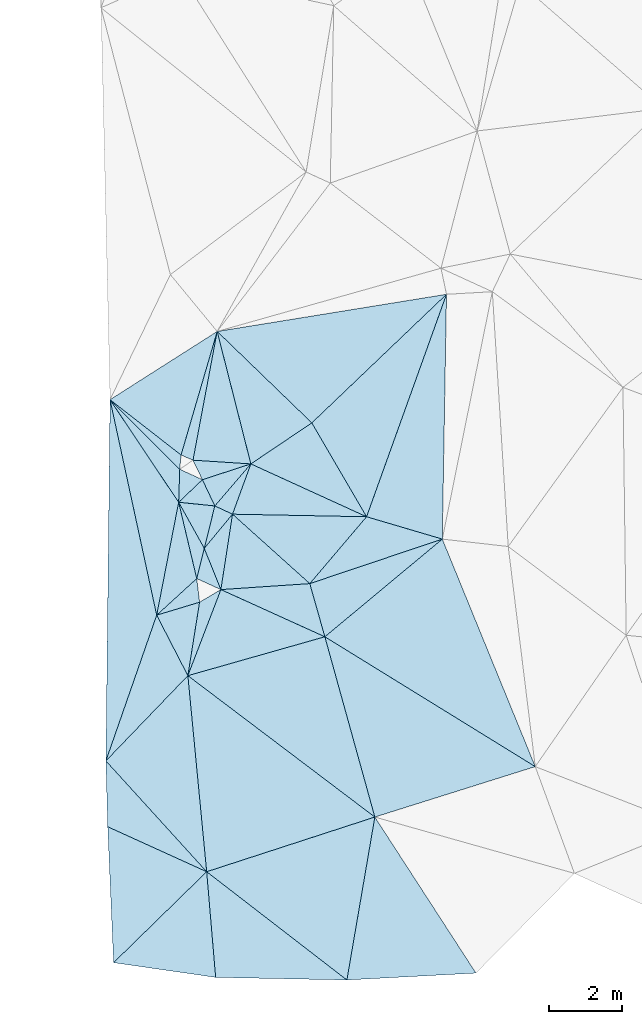
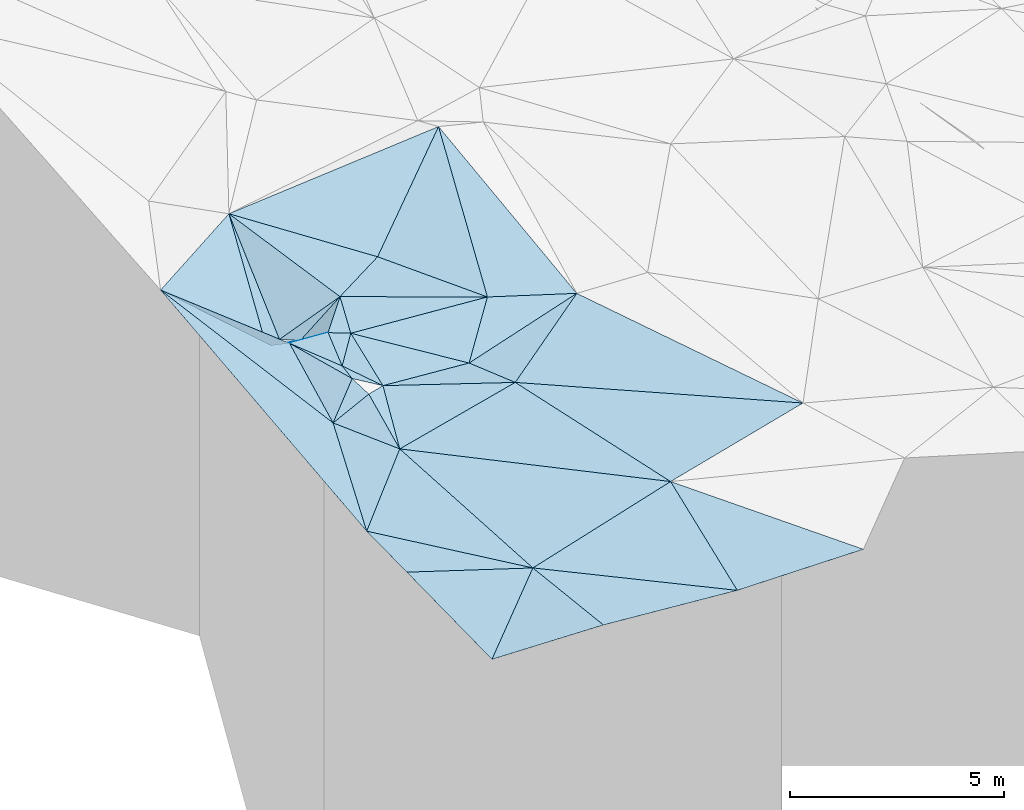
# One storey, part 1 of 275: 45 plates.
"""IFC2X3 building model written with IfcOpenShell, lengths in millimetres."""

from ifc_helpers import new_model, si_unit, frame, origin_with_axes, place, context, subcontext, project, spatial, polyline, outline, extrude, material, type_object, element, save


model = new_model("IFC2X3")

# Units and contexts
model_context = context("Model", 3, precision=1e-05, world=origin_with_axes())
body_context = subcontext(model_context, "Body", "Model", "MODEL_VIEW")
ifc_project = project(units=[si_unit("LENGTHUNIT", "METRE", prefix="MILLI"), si_unit("AREAUNIT", "SQUARE_METRE"), si_unit("VOLUMEUNIT", "CUBIC_METRE"), si_unit("MASSUNIT", "GRAM", prefix="KILO"), si_unit("TIMEUNIT", "SECOND"), si_unit("PLANEANGLEUNIT", "RADIAN"), si_unit("SOLIDANGLEUNIT", "STERADIAN"), si_unit("THERMODYNAMICTEMPERATUREUNIT", "DEGREE_CELSIUS"), si_unit("LUMINOUSINTENSITYUNIT", "LUMEN")], contexts=[model_context])

# Site, building, storey
site_placement = place(None, origin_with_axes())
site = spatial("IfcSite", under=ifc_project, at=site_placement, CompositionType="ELEMENT")
building_placement = place(site_placement, origin_with_axes())
building = spatial("IfcBuilding", under=site, at=building_placement, Name="Undefined", CompositionType="ELEMENT")
storey_placement = place(building_placement, origin_with_axes())
storey = spatial("IfcBuildingStorey", under=building, at=storey_placement, Name="Undefined", CompositionType="ELEMENT", Elevation=0.0)

# Plates
ifc_material = material()
plate_type_1 = type_object("IfcPlateType", PredefinedType="NOTDEFINED")
plate_1_placement = place(storey_placement, frame((-122771.901086998, -17069.5874765673, 43399.5056785177), z_axis=(-0.122261821953716, 0.0880933375109203, -0.988580604087874), x_axis=(-0.190543145478131, -0.979608076552145, -0.0637285341515594)))
element("IfcPlate", 1, at=plate_1_placement, inside=storey, type_object=plate_type_1, material=ifc_material, Name="00", context=body_context, shape_type="SweptSolid", body=[
    extrude(outline(polyline([(0.0, 0.0), (3138.31176757813, 7.4651325121522e-09), (-2410.37255859375, 2390.18920898438), (0.0, 0.0)])), frame((-8.85201319254618e-08, 2.18876761149539e-07, -0.5000001331573), z_axis=(0.0, 0.0, 1.0), x_axis=(1.0, 0.0, 0.0)), (0.0, 0.0, 1.0), 1.0),
])
plate_type_2 = type_object("IfcPlateType", PredefinedType="NOTDEFINED")
plate_2_placement = place(storey_placement, frame((-118790.76655524, -20732.6735217483, 43109.501215455), z_axis=(-0.0446023892570994, 0.0546911228485316, -0.997506645568903), x_axis=(0.849091067725776, -0.524018961721841, -0.0666969749258927)))
element("IfcPlate", 2, at=plate_2_placement, inside=storey, type_object=plate_type_2, material=ifc_material, Name="00", context=body_context, shape_type="SweptSolid", body=[
    extrude(outline(polyline([(0.0, 0.0), (6746.9326171875, -3.48227331414819e-08), (3750.01513671875, 3463.44995117188), (0.0, 0.0)])), frame((-8.85201319254618e-08, 2.18876761149539e-07, -0.5000001331573), z_axis=(0.0, 0.0, 1.0), x_axis=(1.0, 0.0, 0.0)), (0.0, 0.0, 1.0), 1.0),
])
plate_type_3 = type_object("IfcPlateType", PredefinedType="NOTDEFINED")
plate_3_placement = place(storey_placement, frame((-122008.756004514, -27130.1515147808, 42819.5010004084), z_axis=(0.0049591149098023, 0.0640305400789457, -0.997935617721158), x_axis=(-0.672164162510385, 0.739088711640054, 0.0440819119703137)))
element("IfcPlate", 3, at=plate_3_placement, inside=storey, type_object=plate_type_3, material=ifc_material, Name="00", context=body_context, shape_type="SweptSolid", body=[
    extrude(outline(polyline([(0.0, 0.0), (4083.30737304688, 1.52504071593285e-08), (4305.1865234375, 3216.39086914063), (0.0, 0.0)])), frame((-8.85201319254618e-08, 2.18876761149539e-07, -0.5000001331573), z_axis=(0.0, 0.0, 1.0), x_axis=(1.0, 0.0, 0.0)), (0.0, 0.0, 1.0), 1.0),
])
plate_type_4 = type_object("IfcPlateType", PredefinedType="NOTDEFINED")
plate_4_placement = place(storey_placement, frame((-124640.973431471, -14276.8483144081, 43879.5911853084), z_axis=(-0.568042360118678, -0.0944077686572191, -0.817566541834955), x_axis=(0.712030590252748, -0.554551302408187, -0.430680033832202)))
element("IfcPlate", 4, at=plate_4_placement, inside=storey, type_object=plate_type_4, material=ifc_material, Name="00", context=body_context, shape_type="SweptSolid", body=[
    extrude(outline(polyline([(0.0, 0.0), (2716.63403320313, -1.34605215862393e-08), (2875.69116210938, 362.354553222656), (0.0, 0.0)])), frame((-8.85201319254618e-08, 2.18876761149539e-07, -0.5000001331573), z_axis=(0.0, 0.0, 1.0), x_axis=(1.0, 0.0, 0.0)), (0.0, 0.0, 1.0), 1.0),
])
plate_type_5 = type_object("IfcPlateType", PredefinedType="NOTDEFINED")
plate_5_placement = place(storey_placement, frame((-121622.260168616, -19447.8687883034, 43229.5472506555), z_axis=(-0.403899264218134, -0.130575245138853, -0.905436629323653), x_axis=(-0.859822924166915, 0.392142244390839, 0.326999998839712)))
element("IfcPlate", 5, at=plate_5_placement, inside=storey, type_object=plate_type_5, material=ifc_material, Name="00", context=body_context, shape_type="SweptSolid", body=[
    extrude(outline(polyline([(0.0, 0.0), (764.526000976563, -2.8085196390748e-09), (842.613586425781, 870.231201171875), (0.0, 0.0)])), frame((-8.85201319254618e-08, 2.18876761149539e-07, -0.5000001331573), z_axis=(0.0, 0.0, 1.0), x_axis=(1.0, 0.0, 0.0)), (0.0, 0.0, 1.0), 1.0),
])
plate_type_6 = type_object("IfcPlateType", PredefinedType="NOTDEFINED")
plate_6_placement = place(storey_placement, frame((-118190.755606389, -30078.1089354843, 42629.50042643), z_axis=(-0.0208727596487844, 0.0373594143629344, -0.999083881394902), x_axis=(-0.790906232958378, 0.610670304188494, 0.0393587379106559)))
element("IfcPlate", 6, at=plate_6_placement, inside=storey, type_object=plate_type_6, material=ifc_material, Name="00", context=body_context, shape_type="SweptSolid", body=[
    extrude(outline(polyline([(0.0, 0.0), (4827.390625, 1.8524588085711e-08), (2113.25341796875, 3977.34326171875), (0.0, 0.0)])), frame((-8.85201319254618e-08, 2.18876761149539e-07, -0.5000001331573), z_axis=(0.0, 0.0, 1.0), x_axis=(1.0, 0.0, 0.0)), (0.0, 0.0, 1.0), 1.0),
])
plate_type_7 = type_object("IfcPlateType", PredefinedType="NOTDEFINED")
plate_7_placement = place(storey_placement, frame((-122771.902807089, -17069.9118543738, 43399.5907452438), z_axis=(-0.125707812394829, -0.560661978066659, -0.818447122454034), x_axis=(0.0267186955987555, 0.822778908179071, -0.567733193992704)))
element("IfcPlate", 7, at=plate_7_placement, inside=storey, type_object=plate_type_7, material=ifc_material, Name="00", context=body_context, shape_type="SweptSolid", body=[
    extrude(outline(polyline([(0.0, 0.0), (1092.06225585938, 1.81898940354586e-09), (817.718933105469, 630.345703125), (0.0, 0.0)])), frame((-8.85201319254618e-08, 2.18876761149539e-07, -0.5000001331573), z_axis=(0.0, 0.0, 1.0), x_axis=(1.0, 0.0, 0.0)), (0.0, 0.0, 1.0), 1.0),
])
plate_type_8 = type_object("IfcPlateType", PredefinedType="NOTDEFINED")
plate_8_placement = place(storey_placement, frame((-119201.18100862, -19284.931970624, 42929.5095818611), z_axis=(-0.0645970584392301, 0.184147184457356, -0.980773691784923), x_axis=(0.644024990419176, 0.758442326260597, 0.0999852461715997)))
element("IfcPlate", 8, at=plate_8_placement, inside=storey, type_object=plate_type_8, material=ifc_material, Name="00", context=body_context, shape_type="SweptSolid", body=[
    extrude(outline(polyline([(0.0, 0.0), (2400.35424804688, -9.09494701772928e-09), (3242.06323242188, 1993.92224121094), (0.0, 0.0)])), frame((-8.85201319254618e-08, 2.18876761149539e-07, -0.5000001331573), z_axis=(0.0, 0.0, 1.0), x_axis=(1.0, 0.0, 0.0)), (0.0, 0.0, 1.0), 1.0),
])
plate_type_9 = type_object("IfcPlateType", PredefinedType="NOTDEFINED")
plate_9_placement = place(storey_placement, frame((-122074.713447812, -18324.8947062117, 43269.5038947948), z_axis=(0.0324686680568828, 0.12077647697115, -0.992148591797141), x_axis=(-0.483510127395235, 0.870682419423226, 0.0901669629829087)))
element("IfcPlate", 9, at=plate_9_placement, inside=storey, type_object=plate_type_9, material=ifc_material, Name="00", context=body_context, shape_type="SweptSolid", body=[
    extrude(outline(polyline([(0.0, 0.0), (1441.76977539063, 2.3719621822238e-09), (880.029541015625, 815.198120117188), (0.0, 0.0)])), frame((-8.85201319254618e-08, 2.18876761149539e-07, -0.5000001331573), z_axis=(0.0, 0.0, 1.0), x_axis=(1.0, 0.0, 0.0)), (0.0, 0.0, 1.0), 1.0),
])
plate_type_10 = type_object("IfcPlateType", PredefinedType="NOTDEFINED")
plate_10_placement = place(storey_placement, frame((-120806.145398432, -16025.623058627, 43409.5022599292), z_axis=(-0.0767217752915331, 0.0570718504536553, -0.995417788208505), x_axis=(-0.342507677295894, -0.939114085856435, -0.0274449401421353)))
element("IfcPlate", 10, at=plate_10_placement, inside=storey, type_object=plate_type_10, material=ifc_material, Name="00", context=body_context, shape_type="SweptSolid", body=[
    extrude(outline(polyline([(0.0, 0.0), (1457.46350097656, 1.97906047105789e-09), (1410.46411132813, 531.781005859375), (0.0, 0.0)])), frame((-8.85201319254618e-08, 2.18876761149539e-07, -0.5000001331573), z_axis=(0.0, 0.0, 1.0), x_axis=(1.0, 0.0, 0.0)), (0.0, 0.0, 1.0), 1.0),
])
plate_type_11 = type_object("IfcPlateType", PredefinedType="NOTDEFINED")
plate_11_placement = place(storey_placement, frame((-122521.166186553, -21791.4725075276, 43159.500593313), z_axis=(0.0302031740762141, 0.0398057176495703, -0.99875085637917), x_axis=(-0.692371617422149, -0.719832396279217, -0.0496272571794602)))
element("IfcPlate", 11, at=plate_11_placement, inside=storey, type_object=plate_type_11, material=ifc_material, Name="00", context=body_context, shape_type="SweptSolid", body=[
    extrude(outline(polyline([(0.0, 0.0), (3224.03466796875, -4.27826307713985e-09), (-600.36572265625, 1753.78479003906), (0.0, 0.0)])), frame((-8.85201319254618e-08, 2.18876761149539e-07, -0.5000001331573), z_axis=(0.0, 0.0, 1.0), x_axis=(1.0, 0.0, 0.0)), (0.0, 0.0, 1.0), 1.0),
])
plate_type_12 = type_object("IfcPlateType", PredefinedType="NOTDEFINED")
plate_12_placement = place(storey_placement, frame((-122381.701787261, -15923.908466961, 42679.5272972179), z_axis=(0.0521963393186914, 0.321870933641071, -0.945343664620837), x_axis=(-0.914192952191676, 0.39637615140642, 0.0844819078815303)))
element("IfcPlate", 12, at=plate_12_placement, inside=storey, type_object=plate_type_12, material=ifc_material, Name="00", context=body_context, shape_type="SweptSolid", body=[
    extrude(outline(polyline([(0.0, 0.0), (355.105621337891, 1.01863406598568e-09), (891.284118652344, 3666.4033203125), (0.0, 0.0)])), frame((-8.85201319254618e-08, 2.18876761149539e-07, -0.5000001331573), z_axis=(0.0, 0.0, 1.0), x_axis=(1.0, 0.0, 0.0)), (0.0, 0.0, 1.0), 1.0),
])
plate_type_13 = type_object("IfcPlateType", PredefinedType="NOTDEFINED")
plate_13_placement = place(storey_placement, frame((-123369.881048086, -20143.9020445841, 43199.505299668), z_axis=(-0.114639621278769, 0.0898320417217509, -0.989337132383679), x_axis=(-0.328850101341697, -0.943185004974504, -0.0475358521413143)))
element("IfcPlate", 13, at=plate_13_placement, inside=storey, type_object=plate_type_13, material=ifc_material, Name="00", context=body_context, shape_type="SweptSolid", body=[
    extrude(outline(polyline([(0.0, 0.0), (4207.3505859375, -9.00763552635908e-09), (-5148.2041015625, 3161.78662109375), (0.0, 0.0)])), frame((-8.85201319254618e-08, 2.18876761149539e-07, -0.5000001331573), z_axis=(0.0, 0.0, 1.0), x_axis=(1.0, 0.0, 0.0)), (0.0, 0.0, 1.0), 1.0),
])
plate_type_14 = type_object("IfcPlateType", PredefinedType="NOTDEFINED")
plate_14_placement = place(storey_placement, frame((-121622.029114754, -19447.774018182, 43229.5016874103), z_axis=(0.0582038611474905, 0.0589658381668579, -0.996561759489498), x_axis=(-0.373700483485065, 0.926961439555844, 0.0330217840157849)))
element("IfcPlate", 14, at=plate_14_placement, inside=storey, type_object=plate_type_14, material=ifc_material, Name="00", context=body_context, shape_type="SweptSolid", body=[
    extrude(outline(polyline([(0.0, 0.0), (1211.32153320313, -9.31322574615479e-10), (1789.69812011719, 1064.650390625), (0.0, 0.0)])), frame((-8.85201319254618e-08, 2.18876761149539e-07, -0.5000001331573), z_axis=(0.0, 0.0, 1.0), x_axis=(1.0, 0.0, 0.0)), (0.0, 0.0, 1.0), 1.0),
])
plate_type_15 = type_object("IfcPlateType", PredefinedType="NOTDEFINED")
plate_15_placement = place(storey_placement, frame((-117655.247937598, -17464.4630208533, 43169.5010842676), z_axis=(0.0254367876543539, 0.0616895552578082, -0.997771200529421), x_axis=(-0.503425642577036, 0.863087527770596, 0.0405282839846289)))
element("IfcPlate", 15, at=plate_15_placement, inside=storey, type_object=plate_type_15, material=ifc_material, Name="00", context=body_context, shape_type="SweptSolid", body=[
    extrude(outline(polyline([(0.0, 0.0), (2960.89501953125, -1.42608769237995e-09), (4149.69091796875, 4939.044921875), (0.0, 0.0)])), frame((-8.85201319254618e-08, 2.18876761149539e-07, -0.5000001331573), z_axis=(0.0, 0.0, 1.0), x_axis=(1.0, 0.0, 0.0)), (0.0, 0.0, 1.0), 1.0),
])
plate_type_16 = type_object("IfcPlateType", PredefinedType="NOTDEFINED")
plate_16_placement = place(storey_placement, frame((-122279.298527631, -19147.9916298658, 43479.5138526749), z_axis=(0.233339403816212, 0.0178618890881898, -0.97223128706337), x_axis=(-0.725441322748272, -0.66259631259059, -0.186282081238616)))
element("IfcPlate", 16, at=plate_16_placement, inside=storey, type_object=plate_type_16, material=ifc_material, Name="00", context=body_context, shape_type="SweptSolid", body=[
    extrude(outline(polyline([(0.0, 0.0), (1503.09680175781, -5.74073055759072e-09), (-1004.99182128906, 1886.39636230469), (0.0, 0.0)])), frame((-8.85201319254618e-08, 2.18876761149539e-07, -0.5000001331573), z_axis=(0.0, 0.0, 1.0), x_axis=(1.0, 0.0, 0.0)), (0.0, 0.0, 1.0), 1.0),
])
plate_type_17 = type_object("IfcPlateType", PredefinedType="NOTDEFINED")
plate_17_placement = place(storey_placement, frame((-122521.365126509, -21791.4082253854, 43159.5426751291), z_axis=(-0.367673020809544, 0.168368911693717, -0.914586496370823), x_axis=(0.156292660334836, 0.980672451776012, 0.117703639081743)))
element("IfcPlate", 17, at=plate_17_placement, inside=storey, type_object=plate_type_17, material=ifc_material, Name="00", context=body_context, shape_type="SweptSolid", body=[
    extrude(outline(polyline([(0.0, 0.0), (2039.01940917969, 2.6775524020195e-09), (2447.15673828125, 563.581298828125), (0.0, 0.0)])), frame((-8.85201319254618e-08, 2.18876761149539e-07, -0.5000001331573), z_axis=(0.0, 0.0, 1.0), x_axis=(1.0, 0.0, 0.0)), (0.0, 0.0, 1.0), 1.0),
])
plate_type_18 = type_object("IfcPlateType", PredefinedType="NOTDEFINED")
plate_18_placement = place(storey_placement, frame((-122772.041931402, -17069.6968021321, 43399.5472599584), z_axis=(-0.403948627928139, -0.130557985576518, -0.905417096368947), x_axis=(0.483510127395231, -0.870682419425378, -0.0901669629621515)))
element("IfcPlate", 18, at=plate_18_placement, inside=storey, type_object=plate_type_18, material=ifc_material, Name="00", context=body_context, shape_type="SweptSolid", body=[
    extrude(outline(polyline([(0.0, 0.0), (1441.76977539063, 2.3719621822238e-09), (2040.47839355469, 636.355224609375), (0.0, 0.0)])), frame((-8.85201319254618e-08, 2.18876761149539e-07, -0.5000001331573), z_axis=(0.0, 0.0, 1.0), x_axis=(1.0, 0.0, 0.0)), (0.0, 0.0, 1.0), 1.0),
])
plate_type_19 = type_object("IfcPlateType", PredefinedType="NOTDEFINED")
plate_19_placement = place(storey_placement, frame((-121305.363630227, -17394.3325730574, 43369.5060180887), z_axis=(-0.128280532665415, 0.0871422385551784, -0.987901986635653), x_axis=(0.734998548323347, -0.660420095444984, -0.15369590591493)))
element("IfcPlate", 19, at=plate_19_placement, inside=storey, type_object=plate_type_19, material=ifc_material, Name="00", context=body_context, shape_type="SweptSolid", body=[
    extrude(outline(polyline([(0.0, 0.0), (2862.7958984375, -5.23868948221207e-10), (1144.82495117188, 1739.50451660156), (0.0, 0.0)])), frame((-8.85201319254618e-08, 2.18876761149539e-07, -0.5000001331573), z_axis=(0.0, 0.0, 1.0), x_axis=(1.0, 0.0, 0.0)), (0.0, 0.0, 1.0), 1.0),
])
plate_type_20 = type_object("IfcPlateType", PredefinedType="NOTDEFINED")
plate_20_placement = place(storey_placement, frame((-124641.048129942, -14276.9909621945, 43879.7079470699), z_axis=(-0.717439529600976, -0.379702910875678, -0.584042995710476), x_axis=(0.65484677454426, -0.653562173652643, -0.37951572699878)))
element("IfcPlate", 20, at=plate_20_placement, inside=storey, type_object=plate_type_20, material=ifc_material, Name="00", context=body_context, shape_type="SweptSolid", body=[
    extrude(outline(polyline([(0.0, 0.0), (2898.4306640625, 1.09284883365035e-08), (3231.26586914063, 1040.10607910156), (0.0, 0.0)])), frame((-8.85201319254618e-08, 2.18876761149539e-07, -0.5000001331573), z_axis=(0.0, 0.0, 1.0), x_axis=(1.0, 0.0, 0.0)), (0.0, 0.0, 1.0), 1.0),
])
plate_type_21 = type_object("IfcPlateType", PredefinedType="NOTDEFINED")
plate_21_placement = place(storey_placement, frame((-121787.168634267, -17169.9844878022, 43419.505132364), z_axis=(-0.0384023259564882, 0.138102441996449, -0.989673166694818), x_axis=(0.902587642284751, -0.420194738449429, -0.0936585808896901)))
element("IfcPlate", 21, at=plate_21_placement, inside=storey, type_object=plate_type_21, material=ifc_material, Name="00", context=body_context, shape_type="SweptSolid", body=[
    extrude(outline(polyline([(0.0, 0.0), (533.853942871094, -1.3169483281672e-09), (239.765960693359, 1175.37756347656), (0.0, 0.0)])), frame((-8.85201319254618e-08, 2.18876761149539e-07, -0.5000001331573), z_axis=(0.0, 0.0, 1.0), x_axis=(1.0, 0.0, 0.0)), (0.0, 0.0, 1.0), 1.0),
])
plate_type_22 = type_object("IfcPlateType", PredefinedType="NOTDEFINED")
plate_22_placement = place(storey_placement, frame((-122521.111377765, -21791.4444029263, 43159.5072276397), z_axis=(0.139898096599808, 0.095987371430304, -0.985502383098921), x_axis=(-0.457810269651115, 0.888788009807054, 0.0215784759700375)))
element("IfcPlate", 22, at=plate_22_placement, inside=storey, type_object=plate_type_22, material=ifc_material, Name="00", context=body_context, shape_type="SweptSolid", body=[
    extrude(outline(polyline([(0.0, 0.0), (1853.69897460938, -2.6775524020195e-09), (1636.51159667969, 1216.31811523438), (0.0, 0.0)])), frame((-8.85201319254618e-08, 2.18876761149539e-07, -0.5000001331573), z_axis=(0.0, 0.0, 1.0), x_axis=(1.0, 0.0, 0.0)), (0.0, 0.0, 1.0), 1.0),
])
plate_type_23 = type_object("IfcPlateType", PredefinedType="NOTDEFINED")
plate_23_placement = place(storey_placement, frame((-117655.29785001, -17464.492147519, 43169.5013576996), z_axis=(-0.0743890059331714, 0.00343698566071353, -0.997223376644292), x_axis=(-0.907467361076568, 0.414397352357427, 0.0691217978635107)))
element("IfcPlate", 23, at=plate_23_placement, inside=storey, type_object=plate_type_23, material=ifc_material, Name="00", context=body_context, shape_type="SweptSolid", body=[
    extrude(outline(polyline([(0.0, 0.0), (3472.1318359375, -1.19471224024892e-08), (2419.9541015625, 1706.08386230469), (0.0, 0.0)])), frame((-8.85201319254618e-08, 2.18876761149539e-07, -0.5000001331573), z_axis=(0.0, 0.0, 1.0), x_axis=(1.0, 0.0, 0.0)), (0.0, 0.0, 1.0), 1.0),
])
plate_type_24 = type_object("IfcPlateType", PredefinedType="NOTDEFINED")
plate_24_placement = place(storey_placement, frame((-121786.924264653, -17170.2500676977, 43419.5991251531), z_axis=(0.450336976884494, -0.393058173411461, -0.801686896216335), x_axis=(-0.352849858470234, 0.746452353071566, -0.564186017171161)))
element("IfcPlate", 24, at=plate_24_placement, inside=storey, type_object=plate_type_24, material=ifc_material, Name="00", context=body_context, shape_type="SweptSolid", body=[
    extrude(outline(polyline([(0.0, 0.0), (957.131103515625, -1.44063960760832e-09), (513.722717285156, 1417.14111328125), (0.0, 0.0)])), frame((-8.85201319254618e-08, 2.18876761149539e-07, -0.5000001331573), z_axis=(0.0, 0.0, 1.0), x_axis=(1.0, 0.0, 0.0)), (0.0, 0.0, 1.0), 1.0),
])
plate_type_25 = type_object("IfcPlateType", PredefinedType="NOTDEFINED")
plate_25_placement = place(storey_placement, frame((-119201.204377875, -19285.1008653547, 42929.5090520383), z_axis=(-0.111338496507839, -0.153641973437117, -0.981833938705381), x_axis=(0.270812923512108, -0.955276163679709, 0.118776308934918)))
element("IfcPlate", 25, at=plate_25_placement, inside=storey, type_object=plate_type_25, material=ifc_material, Name="00", context=body_context, shape_type="SweptSolid", body=[
    extrude(outline(polyline([(0.0, 0.0), (1515.45373535156, -9.31322574615479e-10), (-464.481353759766, 2400.32446289063), (0.0, 0.0)])), frame((-8.85201319254618e-08, 2.18876761149539e-07, -0.5000001331573), z_axis=(0.0, 0.0, 1.0), x_axis=(1.0, 0.0, 0.0)), (0.0, 0.0, 1.0), 1.0),
])
plate_type_26 = type_object("IfcPlateType", PredefinedType="NOTDEFINED")
plate_26_placement = place(storey_placement, frame((-120805.8963656, -16025.5372264587, 43409.5611773168), z_axis=(0.421339696702426, 0.228733836434522, -0.877584008544284), x_axis=(-0.905798525738672, 0.0583979324666533, -0.419665000033681)))
element("IfcPlate", 26, at=plate_26_placement, inside=storey, type_object=plate_type_26, material=ifc_material, Name="00", context=body_context, shape_type="SweptSolid", body=[
    extrude(outline(polyline([(0.0, 0.0), (1739.48266601563, -1.22599885798991e-08), (831.339111328125, 3662.263671875), (0.0, 0.0)])), frame((-8.85201319254618e-08, 2.18876761149539e-07, -0.5000001331573), z_axis=(0.0, 0.0, 1.0), x_axis=(1.0, 0.0, 0.0)), (0.0, 0.0, 1.0), 1.0),
])
plate_type_27 = type_object("IfcPlateType", PredefinedType="NOTDEFINED")
plate_27_placement = place(storey_placement, frame((-122124.66872447, -16455.6716609789, 42879.5491522523), z_axis=(0.408592172264648, -0.141812281029896, -0.90163280425745), x_axis=(-0.412090197612188, 0.852772869094378, -0.320873967109349)))
element("IfcPlate", 27, at=plate_27_placement, inside=storey, type_object=plate_type_27, material=ifc_material, Name="00", context=body_context, shape_type="SweptSolid", body=[
    extrude(outline(polyline([(0.0, 0.0), (623.297668457031, 2.459273673594e-09), (-346.86474609375, 1443.80908203125), (0.0, 0.0)])), frame((-8.85201319254618e-08, 2.18876761149539e-07, -0.5000001331573), z_axis=(0.0, 0.0, 1.0), x_axis=(1.0, 0.0, 0.0)), (0.0, 0.0, 1.0), 1.0),
])
plate_type_28 = type_object("IfcPlateType", PredefinedType="NOTDEFINED")
plate_28_placement = place(storey_placement, frame((-122008.760679842, -27130.1557502618, 42819.5007453334), z_axis=(-0.00438948595488327, 0.0555588827165584, -0.998445763656865), x_axis=(-0.910090980744347, 0.413527221210731, 0.0270119248763354)))
element("IfcPlate", 28, at=plate_28_placement, inside=storey, type_object=plate_type_28, material=ifc_material, Name="00", context=body_context, shape_type="SweptSolid", body=[
    extrude(outline(polyline([(0.0, 0.0), (2961.65502929688, 6.82484824210405e-09), (3750.74072265625, 1614.10766601563), (0.0, 0.0)])), frame((-8.85201319254618e-08, 2.18876761149539e-07, -0.5000001331573), z_axis=(0.0, 0.0, 1.0), x_axis=(1.0, 0.0, 0.0)), (0.0, 0.0, 1.0), 1.0),
])
plate_type_29 = type_object("IfcPlateType", PredefinedType="NOTDEFINED")
plate_29_placement = place(storey_placement, frame((-119145.889063409, -14908.8990237955, 43289.5083940097), z_axis=(-0.0757486926063099, 0.166358946217218, -0.983151482011766), x_axis=(-0.70854860516117, 0.684764309284835, 0.17046030286792)))
element("IfcPlate", 29, at=plate_29_placement, inside=storey, type_object=plate_type_29, material=ifc_material, Name="00", context=body_context, shape_type="SweptSolid", body=[
    extrude(outline(polyline([(0.0, 0.0), (3637.21044921875, 1.50175765156746e-08), (-147.613128662109, 5077.953125), (0.0, 0.0)])), frame((-8.85201319254618e-08, 2.18876761149539e-07, -0.5000001331573), z_axis=(0.0, 0.0, 1.0), x_axis=(1.0, 0.0, 0.0)), (0.0, 0.0, 1.0), 1.0),
])
plate_type_30 = type_object("IfcPlateType", PredefinedType="NOTDEFINED")
plate_30_placement = place(storey_placement, frame((-115478.690946588, -11407.0876311151, 43599.5046423778), z_axis=(-0.0898447070152488, 0.102609041919114, -0.990656001414106), x_axis=(-0.0171048163800427, -0.994690961030492, -0.101475698080089)))
element("IfcPlate", 30, at=plate_30_placement, inside=storey, type_object=plate_type_30, material=ifc_material, Name="00", context=body_context, shape_type="SweptSolid", body=[
    extrude(outline(polyline([(0.0, 0.0), (6701.11181640625, -2.3283064365387e-10), (6106.0615234375, 2080.89282226563), (0.0, 0.0)])), frame((-8.85201319254618e-08, 2.18876761149539e-07, -0.5000001331573), z_axis=(0.0, 0.0, 1.0), x_axis=(1.0, 0.0, 0.0)), (0.0, 0.0, 1.0), 1.0),
])
plate_type_31 = type_object("IfcPlateType", PredefinedType="NOTDEFINED")
plate_31_placement = place(storey_placement, frame((-113062.019129539, -24268.2149170135, 42659.5012474157), z_axis=(-0.0702240453097026, 0.0131672913466511, -0.997444337243404), x_axis=(-0.849091067724777, 0.524018961723325, 0.0666969749269476)))
element("IfcPlate", 31, at=plate_31_placement, inside=storey, type_object=plate_type_31, material=ifc_material, Name="00", context=body_context, shape_type="SweptSolid", body=[
    extrude(outline(polyline([(0.0, 0.0), (6746.9326171875, -3.48227331414819e-08), (5413.21533203125, 3944.22338867188), (0.0, 0.0)])), frame((-8.85201319254618e-08, 2.18876761149539e-07, -0.5000001331573), z_axis=(0.0, 0.0, 1.0), x_axis=(1.0, 0.0, 0.0)), (0.0, 0.0, 1.0), 1.0),
])
plate_type_32 = type_object("IfcPlateType", PredefinedType="NOTDEFINED")
plate_32_placement = place(storey_placement, frame((-117655.285947758, -17464.4075501817, 43169.5081260111), z_axis=(-0.0505837844027703, 0.172631948290136, -0.983686683443995), x_axis=(-0.644024990419588, -0.758442326262505, -0.0999852461544666)))
element("IfcPlate", 32, at=plate_32_placement, inside=storey, type_object=plate_type_32, material=ifc_material, Name="00", context=body_context, shape_type="SweptSolid", body=[
    extrude(outline(polyline([(0.0, 0.0), (2400.35424804688, -9.09494701772928e-09), (2277.53881835938, 2860.16015625), (0.0, 0.0)])), frame((-8.85201319254618e-08, 2.18876761149539e-07, -0.5000001331573), z_axis=(0.0, 0.0, 1.0), x_axis=(1.0, 0.0, 0.0)), (0.0, 0.0, 1.0), 1.0),
])
plate_type_33 = type_object("IfcPlateType", PredefinedType="NOTDEFINED")
plate_33_placement = place(storey_placement, frame((-121305.326348088, -17394.351774833, 43369.5012857068), z_axis=(-0.0537133770626021, 0.0487373187512885, -0.997366305268764), x_axis=(0.342507677295317, 0.939114085857202, 0.0274449401230491)))
element("IfcPlate", 33, at=plate_33_placement, inside=storey, type_object=plate_type_33, material=ifc_material, Name="00", context=body_context, shape_type="SweptSolid", body=[
    extrude(outline(polyline([(0.0, 0.0), (1457.46350097656, 1.97906047105789e-09), (1178.82873535156, 3460.93383789063), (0.0, 0.0)])), frame((-8.85201319254618e-08, 2.18876761149539e-07, -0.5000001331573), z_axis=(0.0, 0.0, 1.0), x_axis=(1.0, 0.0, 0.0)), (0.0, 0.0, 1.0), 1.0),
])
plate_type_34 = type_object("IfcPlateType", PredefinedType="NOTDEFINED")
plate_34_placement = place(storey_placement, frame((-122706.481640191, -15783.1204508489, 42709.5544954793), z_axis=(-0.237409431524619, 0.387105952110293, -0.89094654366238), x_axis=(-0.712030590250055, 0.554551302407558, 0.430680033837464)))
element("IfcPlate", 34, at=plate_34_placement, inside=storey, type_object=plate_type_34, material=ifc_material, Name="00", context=body_context, shape_type="SweptSolid", body=[
    extrude(outline(polyline([(0.0, 0.0), (2716.63403320313, -1.34605215862393e-08), (1682.67053222656, 3301.3056640625), (0.0, 0.0)])), frame((-8.85201319254618e-08, 2.18876761149539e-07, -0.5000001331573), z_axis=(0.0, 0.0, 1.0), x_axis=(1.0, 0.0, 0.0)), (0.0, 0.0, 1.0), 1.0),
])
plate_type_35 = type_object("IfcPlateType", PredefinedType="NOTDEFINED")
plate_35_placement = place(storey_placement, frame((-121723.061208651, -12418.2997140667, 43909.5074291429), z_axis=(-0.139232294657146, 0.101150448696762, -0.985080176865289), x_axis=(0.708548605160842, -0.684764309282527, -0.170460302878558)))
element("IfcPlate", 35, at=plate_35_placement, inside=storey, type_object=plate_type_35, material=ifc_material, Name="00", context=body_context, shape_type="SweptSolid", body=[
    extrude(outline(polyline([(0.0, 0.0), (3637.21044921875, 1.50175765156746e-08), (3205.03857421875, 1957.30102539063), (0.0, 0.0)])), frame((-8.85201319254618e-08, 2.18876761149539e-07, -0.5000001331573), z_axis=(0.0, 0.0, 1.0), x_axis=(1.0, 0.0, 0.0)), (0.0, 0.0, 1.0), 1.0),
])
plate_type_36 = type_object("IfcPlateType", PredefinedType="NOTDEFINED")
plate_36_placement = place(storey_placement, frame((-122124.896460869, -16455.908913167, 42879.6069185224), z_axis=(-0.0468876235438558, -0.616317213030374, -0.786100911894193), x_axis=(0.352849858469217, -0.746452353073424, 0.564186017169339)))
element("IfcPlate", 36, at=plate_36_placement, inside=storey, type_object=plate_type_36, material=ifc_material, Name="00", context=body_context, shape_type="SweptSolid", body=[
    extrude(outline(polyline([(0.0, 0.0), (957.131103515625, -1.44063960760832e-09), (523.439270019531, 889.9501953125), (0.0, 0.0)])), frame((-8.85201319254618e-08, 2.18876761149539e-07, -0.5000001331573), z_axis=(0.0, 0.0, 1.0), x_axis=(1.0, 0.0, 0.0)), (0.0, 0.0, 1.0), 1.0),
])
plate_type_37 = type_object("IfcPlateType", PredefinedType="NOTDEFINED")
plate_37_placement = place(storey_placement, frame((-118790.759278599, -20732.6714934385, 43109.5010585266), z_axis=(-0.0300481180790049, 0.0587477167001503, -0.997820533153347), x_axis=(0.266632480723518, -0.96162778529077, -0.0646461350738912)))
element("IfcPlate", 37, at=plate_37_placement, inside=storey, type_object=plate_type_37, material=ifc_material, Name="00", context=body_context, shape_type="SweptSolid", body=[
    extrude(outline(polyline([(0.0, 0.0), (5104.71337890625, 4.43833414465189e-09), (20.2753791809082, 3878.05224609375), (0.0, 0.0)])), frame((-8.85201319254618e-08, 2.18876761149539e-07, -0.5000001331573), z_axis=(0.0, 0.0, 1.0), x_axis=(1.0, 0.0, 0.0)), (0.0, 0.0, 1.0), 1.0),
])
plate_type_38 = type_object("IfcPlateType", PredefinedType="NOTDEFINED")
plate_38_placement = place(storey_placement, frame((-122521.193554137, -21791.4727870049, 43159.5005038624), z_axis=(-0.0245276444816986, 0.039245127287096, -0.998928533299755), x_axis=(0.358043069481987, 0.933288887360908, 0.0278749551489337)))
element("IfcPlate", 38, at=plate_38_placement, inside=storey, type_object=plate_type_38, material=ifc_material, Name="00", context=body_context, shape_type="SweptSolid", body=[
    extrude(outline(polyline([(0.0, 0.0), (2511.21484375, 9.45874489843845e-10), (2322.421875, 3105.81030273438), (0.0, 0.0)])), frame((-8.85201319254618e-08, 2.18876761149539e-07, -0.5000001331573), z_axis=(0.0, 0.0, 1.0), x_axis=(1.0, 0.0, 0.0)), (0.0, 0.0, 1.0), 1.0),
])
plate_type_39 = type_object("IfcPlateType", PredefinedType="NOTDEFINED")
plate_39_placement = place(storey_placement, frame((-115593.249635044, -18072.7310363008, 42919.5035118578), z_axis=(0.035363931603094, -0.11343099435003, -0.992916311610568), x_axis=(-0.767956692771996, -0.638874095598069, 0.0456334088190595)))
element("IfcPlate", 39, at=plate_39_placement, inside=storey, type_object=plate_type_39, material=ifc_material, Name="00", context=body_context, shape_type="SweptSolid", body=[
    extrude(outline(polyline([(0.0, 0.0), (4163.6162109375, -8.76752892509103e-09), (3545.69189453125, 1383.751953125), (0.0, 0.0)])), frame((-8.85201319254618e-08, 2.18876761149539e-07, -0.5000001331573), z_axis=(0.0, 0.0, 1.0), x_axis=(1.0, 0.0, 0.0)), (0.0, 0.0, 1.0), 1.0),
])
plate_type_40 = type_object("IfcPlateType", PredefinedType="NOTDEFINED")
plate_40_placement = place(storey_placement, frame((-117429.68708992, -25641.5140106086, 42779.5010576638), z_axis=(-0.0505224535462795, 0.0424030735159899, -0.997822359462876), x_axis=(0.542681948335012, -0.837566970379135, -0.0630703819651708)))
element("IfcPlate", 40, at=plate_40_placement, inside=storey, type_object=plate_type_40, material=ifc_material, Name="00", context=body_context, shape_type="SweptSolid", body=[
    extrude(outline(polyline([(0.0, 0.0), (5073.69677734375, -1.06520019471645e-08), (3312.37768554688, 3051.76245117188), (0.0, 0.0)])), frame((-8.85201319254618e-08, 2.18876761149539e-07, -0.5000001331573), z_axis=(0.0, 0.0, 1.0), x_axis=(1.0, 0.0, 0.0)), (0.0, 0.0, 1.0), 1.0),
])
plate_type_41 = type_object("IfcPlateType", PredefinedType="NOTDEFINED")
plate_41_placement = place(storey_placement, frame((-122521.195531863, -21791.4620060162, 43159.5010970665), z_axis=(-0.0284841923322921, 0.0608082852033295, -0.99774295449169), x_axis=(0.796222790363777, -0.602077994499645, -0.0594252189277203)))
element("IfcPlate", 41, at=plate_41_placement, inside=storey, type_object=plate_type_41, material=ifc_material, Name="00", context=body_context, shape_type="SweptSolid", body=[
    extrude(outline(polyline([(0.0, 0.0), (6394.59130859375, 2.64117261394858e-08), (3642.515625, 3951.18701171875), (0.0, 0.0)])), frame((-8.85201319254618e-08, 2.18876761149539e-07, -0.5000001331573), z_axis=(0.0, 0.0, 1.0), x_axis=(1.0, 0.0, 0.0)), (0.0, 0.0, 1.0), 1.0),
])
plate_type_42 = type_object("IfcPlateType", PredefinedType="NOTDEFINED")
plate_42_placement = place(storey_placement, frame((-118190.776041197, -30078.1354380796, 42629.5009837529), z_axis=(-0.0617433973898585, -0.0156457939101446, -0.997969419377006), x_axis=(-0.997914625513723, 0.0198203113954546, 0.0614292718660532)))
element("IfcPlate", 42, at=plate_42_placement, inside=storey, type_object=plate_type_42, material=ifc_material, Name="00", context=body_context, shape_type="SweptSolid", body=[
    extrude(outline(polyline([(0.0, 0.0), (3581.3544921875, 2.41707311943173e-08), (3880.15209960938, 2871.9541015625), (0.0, 0.0)])), frame((-8.85201319254618e-08, 2.18876761149539e-07, -0.5000001331573), z_axis=(0.0, 0.0, 1.0), x_axis=(1.0, 0.0, 0.0)), (0.0, 0.0, 1.0), 1.0),
])
plate_type_43 = type_object("IfcPlateType", PredefinedType="NOTDEFINED")
plate_43_placement = place(storey_placement, frame((-121764.58660309, -30007.1454647503, 42849.5019625784), z_axis=(0.0891879054352957, -0.00281794728212485, -0.996010831616394), x_axis=(-0.985879817646457, 0.142043592345568, -0.0886825971143971)))
element("IfcPlate", 43, at=plate_43_placement, inside=storey, type_object=plate_type_43, material=ifc_material, Name="00", context=body_context, shape_type="SweptSolid", body=[
    extrude(outline(polyline([(0.0, 0.0), (2819.04248046875, 1.86628312803805e-08), (651.994445800781, 2812.88159179688), (0.0, 0.0)])), frame((-8.85201319254618e-08, 2.18876761149539e-07, -0.5000001331573), z_axis=(0.0, 0.0, 1.0), x_axis=(1.0, 0.0, 0.0)), (0.0, 0.0, 1.0), 1.0),
])
plate_type_44 = type_object("IfcPlateType", PredefinedType="NOTDEFINED")
plate_44_placement = place(storey_placement, frame((-122008.754886901, -27130.1429663406, 42819.5016381222), z_axis=(0.00726789302821358, 0.0810990790688343, -0.99667954584466), x_axis=(-0.713948309565086, -0.697451862502801, -0.0619573301597962)))
element("IfcPlate", 44, at=plate_44_placement, inside=storey, type_object=plate_type_44, material=ifc_material, Name="00", context=body_context, shape_type="SweptSolid", body=[
    extrude(outline(polyline([(0.0, 0.0), (3550.83081054688, 1.229636836797e-08), (1065.21545410156, 2763.4609375), (0.0, 0.0)])), frame((-8.85201319254618e-08, 2.18876761149539e-07, -0.5000001331573), z_axis=(0.0, 0.0, 1.0), x_axis=(1.0, 0.0, 0.0)), (0.0, 0.0, 1.0), 1.0),
])
plate_type_45 = type_object("IfcPlateType", PredefinedType="NOTDEFINED")
plate_45_placement = place(storey_placement, frame((-122202.434098724, -19791.813659907, 43399.5087913522), z_axis=(0.126926789695667, 0.137219156976242, -0.982374924871498), x_axis=(-0.94477763712328, -0.284944202718423, -0.161870373227824)))
element("IfcPlate", 45, at=plate_45_placement, inside=storey, type_object=plate_type_45, material=ifc_material, Name="00", context=body_context, shape_type="SweptSolid", body=[
    extrude(outline(polyline([(0.0, 0.0), (1235.55651855469, -2.60479282587767e-09), (-123.749900817871, 641.549682617188), (0.0, 0.0)])), frame((-8.85201319254618e-08, 2.18876761149539e-07, -0.5000001331573), z_axis=(0.0, 0.0, 1.0), x_axis=(1.0, 0.0, 0.0)), (0.0, 0.0, 1.0), 1.0),
])

save(model, "model.ifc")
